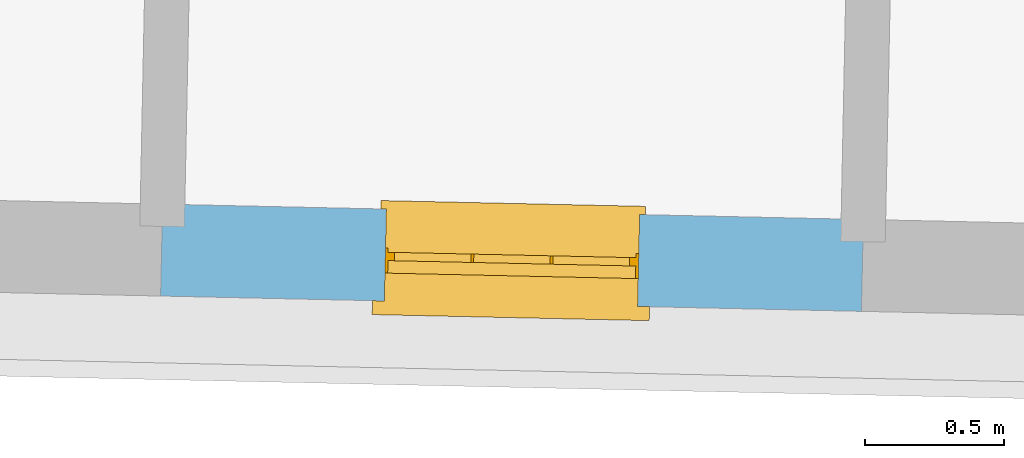
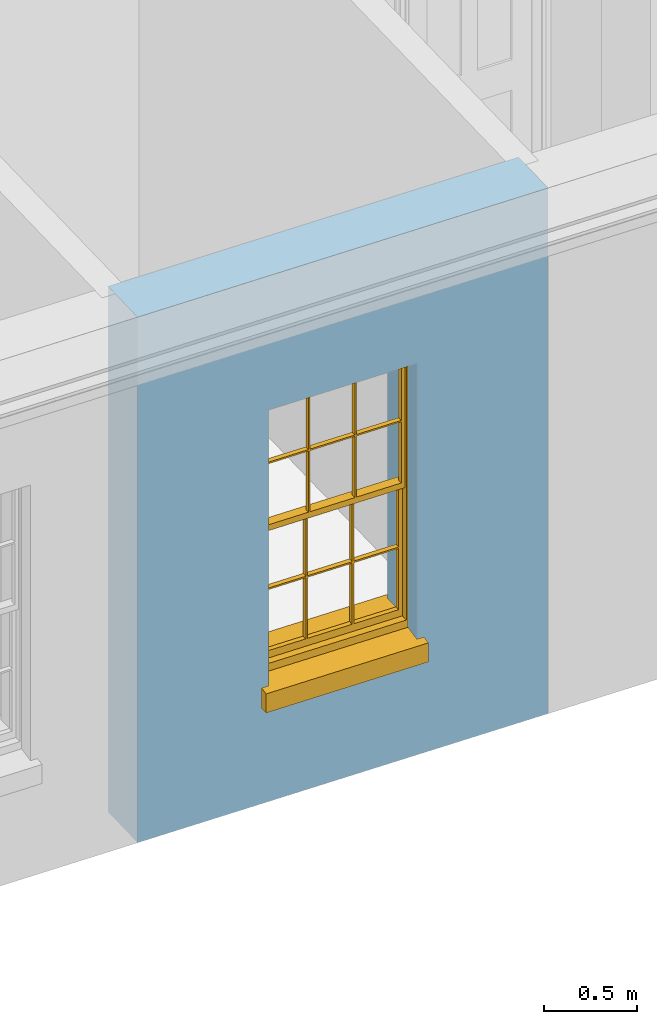
# One storey, part 4 of 14: 1 window, 1 opening, plus 1 element that does not belong to this part.
"""IFC2X3 building model written with IfcOpenShell, lengths in metres."""

from ifc_helpers import new_model, si_unit, frame, origin, place, context, subcontext, project, spatial, polyline, outline, extrude, faceted_brep, material, layer, layer_set, layer_usage, element, fill, save


model = new_model("IFC2X3")

# Units and contexts
model_context = context("Model", 3, world=origin())
body_context = subcontext(model_context, "Body", "Model", "MODEL_VIEW")
ifc_project = project(units=[si_unit("PLANEANGLEUNIT", "RADIAN"), si_unit("MASSUNIT", "GRAM", prefix="KILO"), si_unit("FORCEUNIT", "NEWTON", prefix="KILO"), si_unit("LENGTHUNIT", "METRE")], contexts=[model_context])

# Site, building, storey
site_placement = place(None, origin())
site = spatial("IfcSite", under=ifc_project, at=site_placement, CompositionType="ELEMENT")
building_placement = place(None, origin())
building = spatial("IfcBuilding", under=site, at=building_placement, Name="Building plot-17", CompositionType="ELEMENT")
storey_placement = place(None, frame((0.0, 0.0, 6.15)))
storey = spatial("IfcBuildingStorey", under=building, at=storey_placement, Name="Floor 1", CompositionType="ELEMENT", Elevation=6.15)

# Wall, opening, window
ifc_material = material(Name="Masonry")
ifc_layer = layer(ifc_material, 0.33, ventilated=False)
ifc_layer_set = layer_set([ifc_layer], Name="My Wall")
ifc_layer_usage = layer_usage(ifc_layer_set, "AXIS2", "NEGATIVE", 0.08)
wall_placement = place(storey_placement, origin())
wall = element("IfcWallStandardCase", 1, at=wall_placement, inside=storey, material=ifc_layer_usage, Name="exterior", context=body_context, shape_type="SweptSolid", body=[
    extrude(outline(polyline([(77.2920572225319, 18.6752558575976), (77.2848410882527, 18.3453347649011), (79.8013195426945, 18.2902935843284), (79.8085356769737, 18.6202146770249), (77.2920572225319, 18.6752558575976)])), origin(), (0.0, 0.0, 1.0), 3.45),
])
opening_placement = place(storey_placement, frame((0.0, 0.0, 0.75)))
opening = element("IfcOpeningElement", 2, at=opening_placement, cuts=wall, Name="Opening", ObjectType="Opening", context=body_context, shape_type="SweptSolid", body=[
    extrude(outline(polyline([(78.0881891119072, 18.3277636930906), (78.99797151904, 18.307864656139), (79.0051876533192, 18.6377857488355), (78.0954052461863, 18.6576847857871), (78.0881891119072, 18.3277636930906)])), origin(), (0.0, 0.0, 1.0), 1.82),
])
window_placement = place(storey_placement, frame((78.0936558803005, 18.5777039148304, 0.75), z_axis=(0.0, 0.0, 1.0), x_axis=(0.909782407132823, -0.0198990369516103, 0.0)))
window = element("IfcWindow", 3, at=window_placement, inside=storey, Name="bedroom outside window", OverallHeight=1.82, OverallWidth=0.91, context=body_context, shape_type="Brep", held_by="IfcProductRepresentation", body=[
    faceted_brep([(0.033125, -0.105, 0.975209), (0.01, -0.105, 0.975209), (0.033125, -0.105, 1.376042), (0.876875, -0.105, 0.975209), (0.876875, -0.105, 1.376042), (0.9, -0.105, 0.975209), (0.876875, -0.105, 1.386042), (0.876875, -0.105, 1.786875), (0.9, -0.105, 1.81), (0.033125, -0.105, 1.786875), (0.033125, -0.105, 1.386042), (0.01, -0.105, 1.81), (0.876875, -0.135, 1.376042), (0.876875, -0.135, 0.975209), (0.9, -0.135, 0.937083), (0.033125, -0.135, 1.786875), (0.01, -0.135, 1.81), (0.033125, -0.135, 1.386042), (0.01, -0.135, 0.937083), (0.033125, -0.135, 0.975209), (0.033125, -0.135, 1.376042), (0.876875, -0.135, 1.786875), (0.876875, -0.135, 1.386042), (0.9, -0.135, 1.81), (0.033125, -0.105, 0.937083), (0.01, -0.105, 0.937083), (0.033125, -0.105, 0.53625), (0.876875, -0.105, 0.937083), (0.876875, -0.105, 0.53625), (0.9, -0.105, 0.937083), (0.876875, -0.105, 0.52625), (0.876875, -0.105, 0.125417), (0.9, -0.105, 0.077167), (0.033125, -0.105, 0.125417), (0.033125, -0.105, 0.52625), (0.01, -0.105, 0.077167), (-0.0425, -0.25, 0.01), (-0.0425, -0.3, 0.001667), (0.0, -0.25, 0.01), (0.9525, -0.25, 0.01), (0.91, -0.25, 0.01), (0.9525, -0.3, 0.001667), (-0.02, 0.08, 0.077167), (0.0, 0.08, 0.077167), (-0.02, 0.11, 0.077167), (0.0, -0.06, 0.077167), (0.01, -0.06, 0.077167), (0.91, -0.06, 0.077167), (0.91, 0.08, 0.077167), (0.9, -0.06, 0.077167), (0.93, 0.08, 0.077167), (0.93, 0.11, 0.077167), (0.01, -0.075, 0.975209), (0.9, -0.075, 0.975209), (0.876875, -0.075, 0.125417), (0.876875, -0.075, 0.52625), (0.9, -0.075, 0.077167), (0.876875, -0.075, 0.53625), (0.876875, -0.075, 0.937083), (0.033125, -0.075, 0.125417), (0.01, -0.075, 0.077167), (0.033125, -0.075, 0.52625), (0.033125, -0.075, 0.937083), (0.033125, -0.075, 0.53625), (-0.02, 0.08, 0.052167), (-0.02, 0.11, 0.052167), (0.93, 0.11, 0.052167), (0.93, 0.08, 0.052167), (0.91, 0.08, 0.052167), (0.0, 0.08, 0.052167), (0.91, -0.15, 0.026667), (0.0, -0.15, 0.026667), (-0.0425, -0.3, -0.123333), (0.9525, -0.3, -0.123333), (-0.0425, -0.25, -0.123333), (0.9525, -0.25, -0.123333), (0.01, -0.06, 1.81), (0.9, -0.06, 1.81), (0.0, -0.06, 1.82), (0.91, -0.06, 1.82), (0.01, -0.15, 0.077167), (0.9, -0.15, 0.077167), (0.592292, -0.105, 0.125417), (0.592292, -0.075, 0.125417), (0.317708, -0.075, 0.125417), (0.317708, -0.105, 0.125417), (0.592292, -0.105, 0.53625), (0.317708, -0.105, 0.53625), (0.317708, -0.105, 0.52625), (0.592292, -0.105, 0.52625), (0.592292, -0.075, 0.53625), (0.317708, -0.075, 0.53625), (0.592292, -0.135, 1.386042), (0.592292, -0.105, 1.386042), (0.317708, -0.105, 1.386042), (0.317708, -0.135, 1.386042), (0.317708, -0.135, 1.376042), (0.592292, -0.135, 1.376042), (0.317708, -0.105, 1.376042), (0.592292, -0.105, 1.376042), (0.602292, -0.135, 1.376042), (0.592292, -0.135, 0.975209), (0.602292, -0.135, 0.975209), (0.602292, -0.105, 0.975209), (0.592292, -0.105, 0.975209), (0.602292, -0.105, 1.376042), (0.602292, -0.075, 0.53625), (0.602292, -0.105, 0.53625), (0.317708, -0.075, 0.52625), (0.307708, -0.075, 0.125417), (0.307708, -0.075, 0.52625), (0.602292, -0.075, 0.52625), (0.602292, -0.075, 0.125417), (0.592292, -0.075, 0.52625), (0.307708, -0.075, 0.53625), (0.317708, -0.075, 0.937083), (0.307708, -0.075, 0.937083), (0.602292, -0.075, 0.937083), (0.592292, -0.075, 0.937083), (0.307708, -0.105, 0.52625), (0.307708, -0.105, 0.125417), (0.307708, -0.105, 0.53625), (0.307708, -0.105, 0.937083), (0.592292, -0.105, 0.937083), (0.317708, -0.105, 0.937083), (0.602292, -0.105, 0.937083), (0.602292, -0.105, 0.52625), (0.602292, -0.105, 0.125417), (0.307708, -0.135, 1.386042), (0.307708, -0.135, 1.376042), (0.307708, -0.135, 0.975209), (0.317708, -0.135, 0.975209), (0.317708, -0.135, 1.786875), (0.307708, -0.135, 1.786875), (0.602292, -0.135, 1.786875), (0.592292, -0.135, 1.786875), (0.602292, -0.135, 1.386042), (0.602292, -0.105, 1.386042), (0.307708, -0.105, 1.386042), (0.307708, -0.105, 1.786875), (0.317708, -0.105, 1.786875), (0.592292, -0.105, 1.786875), (0.602292, -0.105, 1.786875), (0.307708, -0.105, 1.376042), (0.317708, -0.105, 0.975209), (0.307708, -0.105, 0.975209), (0.91, -0.15, 1.82), (0.9, -0.15, 1.81), (0.01, -0.15, 1.81), (0.0, -0.15, 1.82), (0.91, -0.25, 0.0), (0.0, -0.25, 0.0), (0.91, 0.08, 0.0), (0.0, 0.08, 0.0)], [[[0, 1, 2]], [[3, 4, 5]], [[6, 7, 8]], [[9, 10, 11]], [[12, 13, 14]], [[15, 16, 17]], [[18, 19, 20]], [[21, 22, 23]], [[24, 25, 26]], [[27, 28, 29]], [[30, 31, 32]], [[33, 34, 35]], [[14, 27, 29]], [[25, 24, 18]], [[36, 37, 38]], [[39, 40, 41]], [[42, 43, 44]], [[45, 46, 43]], [[47, 48, 49]], [[50, 51, 48]], [[1, 0, 52]], [[5, 53, 3]], [[54, 55, 56]], [[57, 58, 53]], [[59, 60, 61]], [[62, 63, 52]], [[48, 43, 46, 49]], [[51, 44, 43, 48]], [[64, 42, 44, 65]], [[65, 44, 51, 66]], [[66, 51, 50, 67]], [[65, 66, 68, 69]], [[60, 56, 49, 46]], [[70, 71, 38, 40]], [[37, 41, 40, 38]], [[37, 72, 73, 41]], [[74, 75, 73, 72]], [[8, 11, 76, 77]], [[76, 78, 79, 77]], [[32, 35, 80, 81]], [[81, 80, 71, 70]], [[82, 83, 84, 85]], [[86, 87, 88, 89]], [[86, 90, 91, 87]], [[92, 93, 94, 95]], [[92, 95, 96, 97]], [[96, 98, 99, 97]], [[100, 97, 101, 102]], [[103, 104, 99, 105]], [[97, 99, 104, 101]], [[102, 103, 105, 100]], [[28, 57, 106, 107]], [[108, 84, 109, 110]], [[111, 112, 83, 113]], [[114, 110, 61, 63]], [[90, 113, 108, 91]], [[115, 91, 114, 116]], [[117, 106, 90, 118]], [[111, 106, 57, 55]], [[119, 110, 109, 120]], [[34, 61, 110, 119]], [[89, 113, 83, 82]], [[88, 108, 113, 89]], [[85, 84, 108, 88]], [[121, 114, 63, 26]], [[122, 116, 114, 121]], [[123, 118, 90, 86]], [[87, 91, 115, 124]], [[107, 106, 117, 125]], [[126, 111, 55, 30]], [[127, 112, 111, 126]], [[126, 30, 28, 107]], [[88, 119, 120, 85]], [[126, 89, 82, 127]], [[125, 123, 86, 107]], [[121, 26, 34, 119]], [[124, 122, 121, 87]], [[128, 17, 20, 129]], [[96, 129, 130, 131]], [[132, 133, 128, 95]], [[134, 135, 92, 136]], [[100, 12, 22, 136]], [[137, 6, 4, 105]], [[94, 138, 139, 140]], [[137, 93, 141, 142]], [[99, 98, 94, 93]], [[143, 2, 10, 138]], [[144, 145, 143, 98]], [[129, 143, 145, 130]], [[20, 2, 143, 129]], [[131, 144, 98, 96]], [[128, 138, 10, 17]], [[133, 139, 138, 128]], [[135, 141, 93, 92]], [[95, 94, 140, 132]], [[22, 6, 137, 136]], [[136, 137, 142, 134]], [[100, 105, 4, 12]], [[107, 86, 89, 126]], [[106, 111, 113, 90]], [[91, 108, 110, 114]], [[87, 121, 119, 88]], [[97, 100, 136, 92]], [[129, 96, 95, 128]], [[98, 143, 138, 94]], [[105, 99, 93, 137]], [[131, 101, 104, 144]], [[124, 115, 118, 123]], [[132, 140, 141, 135]], [[120, 109, 59, 33]], [[15, 9, 139, 133]], [[134, 142, 7, 21]], [[31, 54, 112, 127]], [[36, 74, 72, 37]], [[39, 41, 73, 75]], [[18, 14, 101, 131]], [[23, 16, 132, 135]], [[83, 56, 60, 84]], [[52, 53, 118, 115]], [[53, 52, 144, 104]], [[11, 8, 141, 140]], [[14, 18, 124, 123]], [[2, 1, 11, 10]], [[8, 5, 4, 6]], [[57, 53, 56, 55]], [[60, 52, 63, 61]], [[26, 25, 35, 34]], [[32, 29, 28, 30]], [[14, 23, 22, 12]], [[18, 20, 17, 16]], [[19, 0, 2, 20]], [[17, 10, 9, 15]], [[12, 4, 3, 13]], [[21, 7, 6, 22]], [[27, 58, 57, 28]], [[30, 55, 54, 31]], [[33, 59, 61, 34]], [[26, 63, 62, 24]], [[5, 8, 77, 53]], [[76, 11, 1, 52]], [[46, 45, 78, 76]], [[49, 77, 79, 47]], [[70, 146, 147, 81]], [[71, 80, 148, 149]], [[19, 130, 145, 0]], [[102, 13, 3, 103]], [[116, 122, 24, 62]], [[29, 32, 81, 14]], [[80, 35, 25, 18]], [[60, 46, 76, 52]], [[77, 49, 56, 53]], [[23, 14, 81, 147]], [[16, 148, 80, 18]], [[35, 85, 120]], [[120, 33, 35]], [[127, 82, 32]], [[32, 31, 127]], [[32, 82, 85, 35]], [[102, 101, 14]], [[14, 13, 102]], [[18, 131, 130]], [[130, 19, 18]], [[134, 21, 23]], [[23, 135, 134]], [[16, 15, 133]], [[133, 132, 16]], [[11, 140, 139]], [[139, 9, 11]], [[142, 141, 8]], [[8, 7, 142]], [[23, 147, 148, 16]], [[146, 149, 148, 147]], [[52, 115, 116]], [[116, 62, 52]], [[118, 53, 117]], [[58, 117, 53]], [[27, 125, 117, 58]], [[56, 83, 112]], [[112, 54, 56]], [[109, 84, 60]], [[60, 59, 109]], [[125, 27, 14]], [[14, 123, 125]], [[122, 124, 18]], [[18, 24, 122]], [[145, 144, 52]], [[52, 0, 145]], [[103, 3, 53]], [[53, 104, 103]], [[79, 78, 149, 146]], [[78, 45, 71, 149]], [[146, 70, 47, 79]], [[150, 75, 74, 151]], [[68, 66, 67]], [[48, 68, 67, 50]], [[69, 64, 65]], [[42, 64, 69, 43]], [[69, 68, 152, 153]], [[70, 68, 48, 47]], [[150, 152, 68, 70]], [[43, 69, 71, 45]], [[69, 153, 151, 71]], [[152, 150, 151, 153]], [[38, 151, 74, 36]], [[71, 151, 38]], [[39, 75, 150, 40]], [[40, 150, 70]]]),
])
fill(opening, window)

save(model, "model.ifc")
